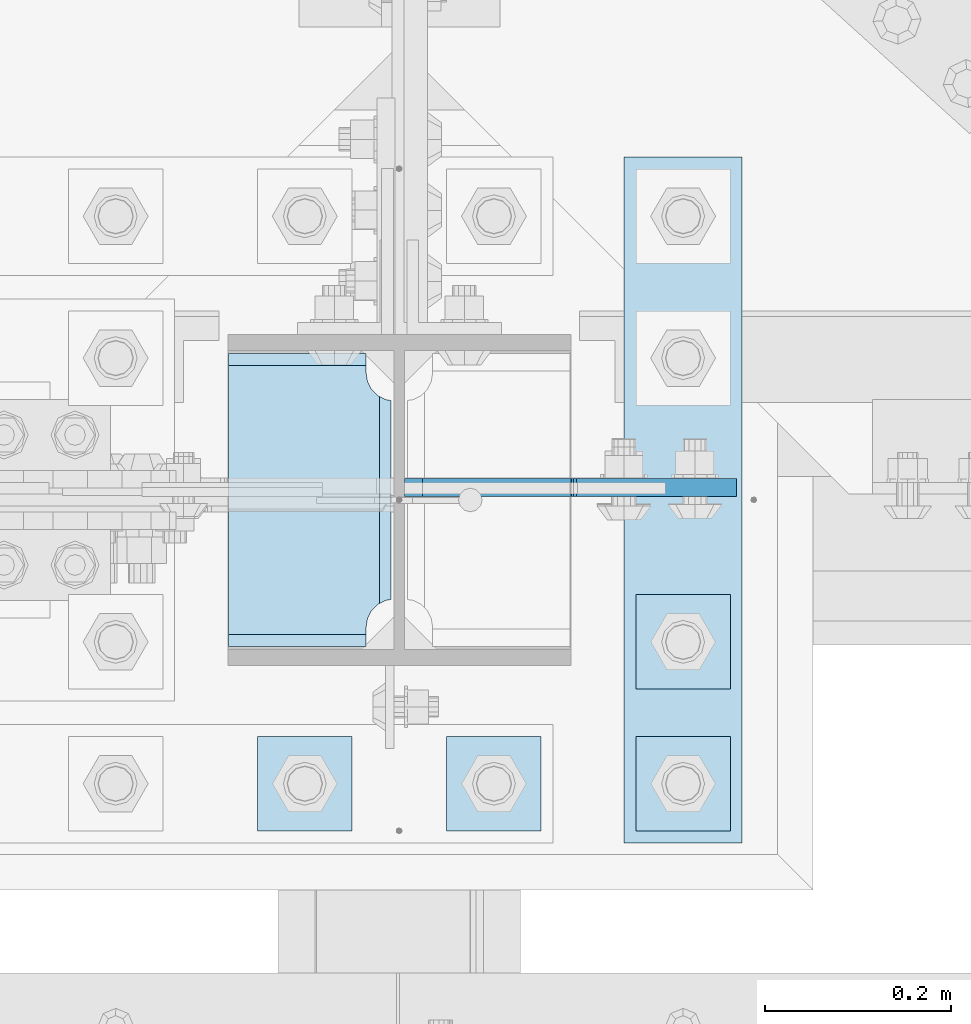
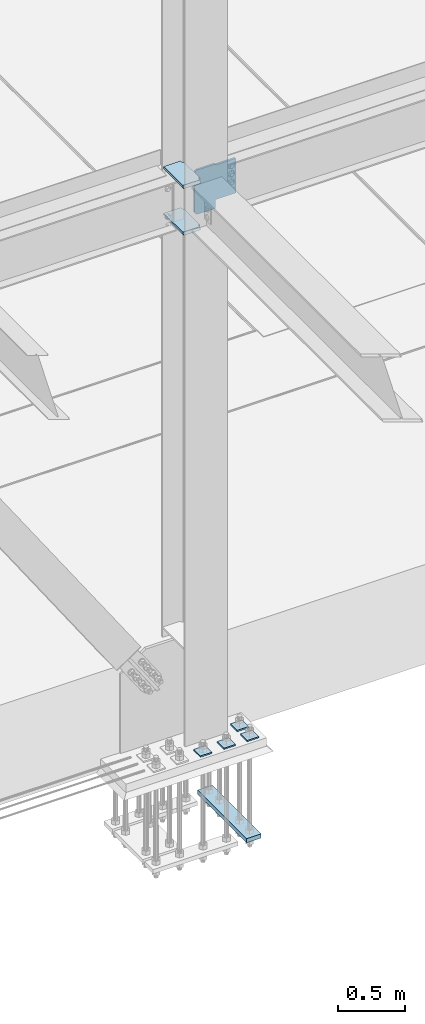
# One storey, part 3184 of 3843: 8 plates, 2 elements without a shape of their own.
"""IFC2X3 building model written with IfcOpenShell, lengths in millimetres."""

from ifc_helpers import new_model, si_unit, frame, origin_with_axes, place, context, subcontext, project, spatial, faceted_brep, material, type_object, element, aggregate, save


model = new_model("IFC2X3")

# Units and contexts
model_context = context("Model", 3, precision=1e-05, world=origin_with_axes())
body_context = subcontext(model_context, "Body", "Model", "MODEL_VIEW")
ifc_project = project(units=[si_unit("LENGTHUNIT", "METRE", prefix="MILLI"), si_unit("AREAUNIT", "SQUARE_METRE"), si_unit("VOLUMEUNIT", "CUBIC_METRE"), si_unit("MASSUNIT", "GRAM", prefix="KILO"), si_unit("TIMEUNIT", "SECOND"), si_unit("PLANEANGLEUNIT", "RADIAN"), si_unit("SOLIDANGLEUNIT", "STERADIAN"), si_unit("THERMODYNAMICTEMPERATUREUNIT", "DEGREE_CELSIUS"), si_unit("LUMINOUSINTENSITYUNIT", "LUMEN")], contexts=[model_context])

# Site, building, storey
site_placement = place(None, origin_with_axes())
site = spatial("IfcSite", under=ifc_project, at=site_placement, CompositionType="ELEMENT")
building_placement = place(site_placement, origin_with_axes())
building = spatial("IfcBuilding", under=site, at=building_placement, Name="Undefined", CompositionType="ELEMENT")
storey_placement = place(building_placement, origin_with_axes())
storey = spatial("IfcBuildingStorey", under=building, at=storey_placement, Name="Undefined", CompositionType="ELEMENT", Elevation=0.0)

# Assembly, plates
assembly_1_placement = place(storey_placement, origin_with_axes())
assembly_1 = element("IfcElementAssembly", 1, at=assembly_1_placement, inside=storey, Name="COLUMN", AssemblyPlace="NOTDEFINED", PredefinedType="RIGID_FRAME")
ifc_material = material(Name="STEEL/A572-50")
plate_type_1 = type_object("IfcPlateType", PredefinedType="NOTDEFINED")
plate_1_placement = place(assembly_1_placement, frame((62453.04375, 25776.2375, 34370.9625), z_axis=(0.0, -1.0, 0.0), x_axis=(1.0, 0.0, 0.0)))
plate_1 = element("IfcPlate", 2, at=plate_1_placement, type_object=plate_type_1, material=ifc_material, Name="PLATE", context=body_context, shape_type="Brep", body=[
    faceted_brep([(161.793390094695, 11.1125000000029, 49.092112223927), (161.793390094695, 11.1125000000029, 271.582887776072), (168.479274789279, -0.467791984563519, 268.176259371798), (174.625000047679, -11.1125000000029, 267.202872116355), (174.625000047679, -11.1125000000029, 53.4721278836441), (168.479274789279, -0.467791984563519, 52.4987406282016), (147.637499618526, 11.1125000000029, 16.0071099052948), (147.637499618526, -11.1125000000029, 3.17549995231457), (0.0, -11.1125000000029, 3.17549995231457), (0.0, 11.1125000000029, 16.0071099052948), (0.0, 11.1125000000029, 304.668890094701), (0.0, -11.1125000000029, 317.500500047681), (147.637499618526, -11.1125000000029, 317.500500047681), (147.637499618526, 11.1125000000029, 304.668890094701), (147.637499618526, -11.1125000000029, 296.862501907348), (147.637499618526, 11.1125000000029, 296.862501907348), (149.113757464445, -11.1125000000029, 287.541776696635), (149.113757464445, 11.1125000000029, 287.541776696635), (153.398024598544, -11.1125000000029, 279.133429010853), (153.398024598544, 11.1125000000029, 279.133429010853), (160.070927103501, -11.1125000000029, 272.4605265059), (160.070927103501, 11.1125000000029, 272.4605265059), (168.479274789279, -11.1125000000029, 268.176259371798), (168.479274789279, -11.1125000000029, 52.4987406282016), (160.070927103501, -11.1125000000029, 48.214473494103), (160.070927103501, 11.1125000000029, 48.214473494103), (153.398024598544, -11.1125000000029, 41.5415709891458), (153.398024598544, 11.1125000000029, 41.5415709891458), (149.113757464445, -11.1125000000029, 33.1332233033681), (149.113757464445, 11.1125000000029, 33.1332233033681), (147.637499618526, -11.1125000000029, 23.8124980926514), (147.637499618526, 11.1125000000029, 23.8124980926514)], [[[0, 1, 2, 3, 4, 5]], [[6, 7, 8, 9]], [[10, 11, 12, 13]], [[11, 10, 9, 8]], [[14, 15, 13, 12]], [[14, 16, 17, 15]], [[16, 18, 19, 17]], [[18, 20, 21, 19]], [[21, 20, 22, 2, 1]], [[22, 3, 2]], [[23, 5, 4]], [[23, 24, 25, 0, 5]], [[24, 26, 27, 25]], [[26, 28, 29, 27]], [[28, 30, 31, 29]], [[31, 30, 7, 6]], [[25, 27, 29, 31, 6, 9, 10, 13, 15, 17, 19, 21, 1, 0]], [[7, 30, 28, 26, 24, 23, 4, 3, 22, 20, 18, 16, 14, 12, 11, 8]]]),
])
plate_2_placement = place(assembly_1_placement, frame((62453.04375, 25776.2375, 34799.5875), z_axis=(0.0, -1.0, 0.0), x_axis=(1.0, 0.0, 0.0)))
plate_2 = element("IfcPlate", 3, at=plate_2_placement, type_object=plate_type_1, material=ifc_material, Name="PLATE", context=body_context, shape_type="Brep", body=[
    faceted_brep([(161.793390094695, 11.1125000000029, 49.092112223927), (161.793390094695, 11.1125000000029, 271.582887776072), (168.479274789279, -0.467791984563519, 268.176259371798), (174.625000047679, -11.1125000000029, 267.202872116355), (174.625000047679, -11.1125000000029, 53.4721278836441), (168.479274789279, -0.467791984563519, 52.4987406282016), (147.637499618526, 11.1125000000029, 16.0071099052948), (147.637499618526, -11.1125000000029, 3.17549995231457), (0.0, -11.1125000000029, 3.17549995231457), (0.0, 11.1125000000029, 16.0071099052948), (0.0, 11.1125000000029, 304.668890094701), (0.0, -11.1125000000029, 317.500500047681), (147.637499618526, -11.1125000000029, 317.500500047681), (147.637499618526, 11.1125000000029, 304.668890094701), (147.637499618526, -11.1125000000029, 296.862501907348), (147.637499618526, 11.1125000000029, 296.862501907348), (149.113757464445, -11.1125000000029, 287.541776696635), (149.113757464445, 11.1125000000029, 287.541776696635), (153.398024598544, -11.1125000000029, 279.133429010853), (153.398024598544, 11.1125000000029, 279.133429010853), (160.070927103501, -11.1125000000029, 272.4605265059), (160.070927103501, 11.1125000000029, 272.4605265059), (168.479274789279, -11.1125000000029, 268.176259371798), (168.479274789279, -11.1125000000029, 52.4987406282016), (160.070927103501, -11.1125000000029, 48.214473494103), (160.070927103501, 11.1125000000029, 48.214473494103), (153.398024598544, -11.1125000000029, 41.5415709891458), (153.398024598544, 11.1125000000029, 41.5415709891458), (149.113757464445, -11.1125000000029, 33.1332233033681), (149.113757464445, 11.1125000000029, 33.1332233033681), (147.637499618526, -11.1125000000029, 23.8124980926514), (147.637499618526, 11.1125000000029, 23.8124980926514)], [[[0, 1, 2, 3, 4, 5]], [[6, 7, 8, 9]], [[10, 11, 12, 13]], [[11, 10, 9, 8]], [[14, 15, 13, 12]], [[14, 16, 17, 15]], [[16, 18, 19, 17]], [[18, 20, 21, 19]], [[21, 20, 22, 2, 1]], [[22, 3, 2]], [[23, 5, 4]], [[23, 24, 25, 0, 5]], [[24, 26, 27, 25]], [[26, 28, 29, 27]], [[28, 30, 31, 29]], [[31, 30, 7, 6]], [[25, 27, 29, 31, 6, 9, 10, 13, 15, 17, 19, 21, 1, 0]], [[7, 30, 28, 26, 24, 23, 4, 3, 22, 20, 18, 16, 14, 12, 11, 8]]]),
])

assembly_2_placement = place(storey_placement, origin_with_axes())
assembly_2 = element("IfcElementAssembly", 4, at=assembly_2_placement, inside=storey, Name="TEMPLATE", AssemblyPlace="NOTDEFINED", PredefinedType="RIGID_FRAME")
plate_type_2 = type_object("IfcPlateType", PredefinedType="NOTDEFINED")
plate_3_placement = place(assembly_2_placement, frame((62585.6, 25361.9, 29686.25), z_axis=(-1.0, 0.0, 0.0), x_axis=(0.0, -1.0, 0.0)))
plate_3 = element("IfcPlate", 5, at=plate_3_placement, type_object=plate_type_2, material=ifc_material, Name="Washer Plate", context=body_context, shape_type="Brep", body=[
    faceted_brep([(0.0, -6.3499999046162, 0.0), (-1.67347025126219e-10, -6.35000000000582, 101.600000000151), (-1.67347025126219e-10, 6.35000000000582, 101.600000000151), (7.27595761418343e-12, 6.3499999046162, 0.0), (101.599998474121, -6.34999999999854, 101.599998474121), (101.599998474121, 6.34999999999854, 101.599998474121), (101.6, -6.34999999999854, 0.0), (101.6, 6.34999999999854, 0.0)], [[[0, 1, 2, 3]], [[1, 4, 5, 2]], [[4, 6, 7, 5]], [[6, 0, 3, 7]], [[5, 7, 3, 2]], [[6, 4, 1, 0]]]),
])
plate_4_placement = place(assembly_2_placement, frame((62788.8, 25361.9, 29686.25), z_axis=(-1.0, 0.0, 0.0), x_axis=(0.0, -1.0, 0.0)))
plate_4 = element("IfcPlate", 6, at=plate_4_placement, type_object=plate_type_2, material=ifc_material, Name="Washer Plate", context=body_context, shape_type="Brep", body=[
    faceted_brep([(0.0, -6.3499999046162, 0.0), (-1.67347025126219e-10, -6.35000000000582, 101.600000000151), (-1.67347025126219e-10, 6.35000000000582, 101.600000000151), (7.27595761418343e-12, 6.3499999046162, 0.0), (101.599998474121, -6.34999999999854, 101.599998474121), (101.599998474121, 6.34999999999854, 101.599998474121), (101.6, -6.34999999999854, 0.0), (101.6, 6.34999999999854, 0.0)], [[[0, 1, 2, 3]], [[1, 4, 5, 2]], [[4, 6, 7, 5]], [[6, 0, 3, 7]], [[5, 7, 3, 2]], [[6, 4, 1, 0]]]),
])
plate_5_placement = place(assembly_2_placement, frame((62992.0, 25361.9, 29686.25), z_axis=(-1.0, 0.0, 0.0), x_axis=(0.0, -1.0, 0.0)))
plate_5 = element("IfcPlate", 7, at=plate_5_placement, type_object=plate_type_2, material=ifc_material, Name="Washer Plate", context=body_context, shape_type="Brep", body=[
    faceted_brep([(0.0, -6.3499999046162, 0.0), (-1.67347025126219e-10, -6.35000000000582, 101.600000000151), (-1.67347025126219e-10, 6.35000000000582, 101.600000000151), (7.27595761418343e-12, 6.3499999046162, 0.0), (101.599998474121, -6.34999999999854, 101.599998474121), (101.599998474121, 6.34999999999854, 101.599998474121), (101.6, -6.34999999999854, 0.0), (101.6, 6.34999999999854, 0.0)], [[[0, 1, 2, 3]], [[1, 4, 5, 2]], [[4, 6, 7, 5]], [[6, 0, 3, 7]], [[5, 7, 3, 2]], [[6, 4, 1, 0]]]),
])
plate_6_placement = place(assembly_2_placement, frame((62992.0, 25514.3, 29686.25), z_axis=(-1.0, 0.0, 0.0), x_axis=(0.0, -1.0, 0.0)))
plate_6 = element("IfcPlate", 8, at=plate_6_placement, type_object=plate_type_2, material=ifc_material, Name="Washer Plate", context=body_context, shape_type="Brep", body=[
    faceted_brep([(0.0, -6.3499999046162, 0.0), (-1.67347025126219e-10, -6.35000000000582, 101.600000000151), (-1.67347025126219e-10, 6.35000000000582, 101.600000000151), (7.27595761418343e-12, 6.3499999046162, 0.0), (101.599998474121, -6.34999999999854, 101.599998474121), (101.599998474121, 6.34999999999854, 101.599998474121), (101.6, -6.34999999999854, 0.0), (101.6, 6.34999999999854, 0.0)], [[[0, 1, 2, 3]], [[1, 4, 5, 2]], [[4, 6, 7, 5]], [[6, 0, 3, 7]], [[5, 7, 3, 2]], [[6, 4, 1, 0]]]),
])

# Plate
plate_type_3 = type_object("IfcPlateType", PredefinedType="NOTDEFINED")
plate_7_placement = place(assembly_1_placement, frame((62641.95625, 25629.3937503815, 34401.1250026613), z_axis=(0.707106781186548, 0.0, 0.707106781186548), x_axis=(0.707106781186548, 0.0, -0.707106781186548)))
plate_7 = element("IfcPlate", 9, at=plate_7_placement, type_object=plate_type_3, material=ifc_material, Name="PLATE", context=body_context, shape_type="Brep", body=[
    faceted_brep([(0.0, -9.52500000000146, 0.0), (-260.427429450454, -9.52500000000146, 260.427425569054), (-260.427429450454, 9.52500000000146, 260.427425569054), (0.0, 9.52500000000146, 0.0), (-260.427429450483, -9.52500000000146, 287.368193731425), (-260.427429450483, 9.52500000000146, 287.368193731425), (-147.61296128836, -9.52500000000146, 400.182659673344), (-147.61296128836, 9.52500000000146, 400.182659673344), (-144.522828999212, -9.52500000000146, 398.117899322693), (-144.522828999212, 9.52500000000146, 398.117899322693), (-140.877769446524, -9.52500000000146, 397.392851926066), (-140.877769446524, 9.52500000000146, 397.392851926066), (-137.232709904638, -9.52500000000146, 398.11789937703), (-137.232709904638, 9.52500000000146, 398.11789937703), (-134.14257764626, -9.52500000000146, 400.182659773724), (-134.14257764626, 9.52500000000146, 400.182659773724), (-15.154180712063, -9.52500000000146, 519.171058481312), (-15.154180712063, 9.52500000000146, 519.171058481312), (209.352223986596, -9.52500000000146, 294.664657128669), (209.352223986596, 9.52500000000146, 294.664657128669), (92.6088912007945, -9.52500000000146, 177.921322602953), (92.6088912007945, 9.52500000000146, 177.921322602953), (89.8558773310324, -9.52500000000146, 173.801146114289), (89.8558773310324, 9.52500000000146, 173.801146114289), (88.8891474446573, -9.52500000000146, 168.941066589061), (88.8891474446573, 9.52500000000146, 168.941066589061), (89.8558774034609, -9.52500000000146, 164.080987078225), (89.8558774034609, 9.52500000000146, 164.080987078225), (92.6088913346393, -9.52500000000146, 159.960810630597), (92.6088913346393, 9.52500000000146, 159.960810630597), (139.755236456211, -9.52500000000146, 112.814466211697), (139.755236456211, 9.52500000000146, 112.814466211697), (26.9407683632344, -9.52499999999964, 2.03726813197136e-10), (26.9407683632344, 9.52499999999964, 2.03726813197136e-10)], [[[0, 1, 2, 3]], [[1, 4, 5, 2]], [[4, 6, 7, 5]], [[6, 8, 9, 7]], [[8, 10, 11, 9]], [[10, 12, 13, 11]], [[12, 14, 15, 13]], [[14, 16, 17, 15]], [[16, 18, 19, 17]], [[18, 20, 21, 19]], [[20, 22, 23, 21]], [[22, 24, 25, 23]], [[24, 26, 27, 25]], [[26, 28, 29, 27]], [[28, 30, 31, 29]], [[30, 32, 33, 31]], [[32, 0, 3, 33]], [[5, 7, 9, 11, 13, 15, 17, 19, 21, 23, 25, 27, 29, 31, 33, 3, 2]], [[32, 30, 28, 26, 24, 22, 20, 18, 16, 14, 12, 10, 8, 6, 4, 1, 0]]]),
])

aggregate(assembly_1, [plate_7, plate_1, plate_2])

plate_type_4 = type_object("IfcPlateType", PredefinedType="NOTDEFINED")
plate_8_placement = place(assembly_2_placement, frame((63004.7, 25984.2, 28784.55), z_axis=(-1.0, 0.0, 0.0), x_axis=(0.0, -1.0, 0.0)))
plate_8 = element("IfcPlate", 10, at=plate_8_placement, type_object=plate_type_4, material=ifc_material, Name="PLATE", context=body_context, shape_type="Brep", body=[
    faceted_brep([(0.0, -19.0500000000029, 0.0), (0.0, -19.0499999999993, 127.0), (0.0, 19.0499999999993, 127.0), (0.0, 19.0500000000029, 0.0), (736.599975585938, -19.0499999999993, 127.0), (736.599975585938, 19.0499999999993, 127.0), (736.599975585938, -19.0499999999993, 0.0), (736.599975585938, 19.0499999999993, 0.0)], [[[0, 1, 2, 3]], [[1, 4, 5, 2]], [[4, 6, 7, 5]], [[6, 0, 3, 7]], [[5, 7, 3, 2]], [[6, 4, 1, 0]]]),
])

aggregate(assembly_2, [plate_3, plate_4, plate_5, plate_6, plate_8])

save(model, "model.ifc")
